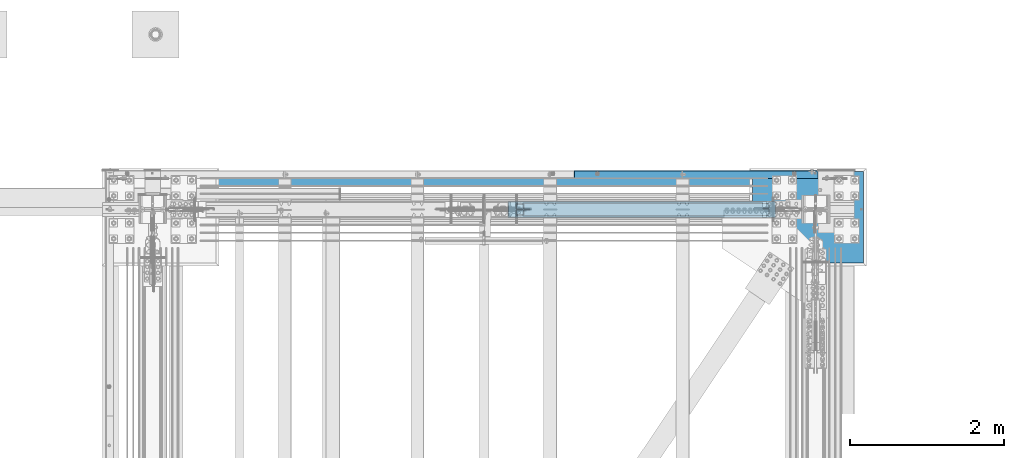
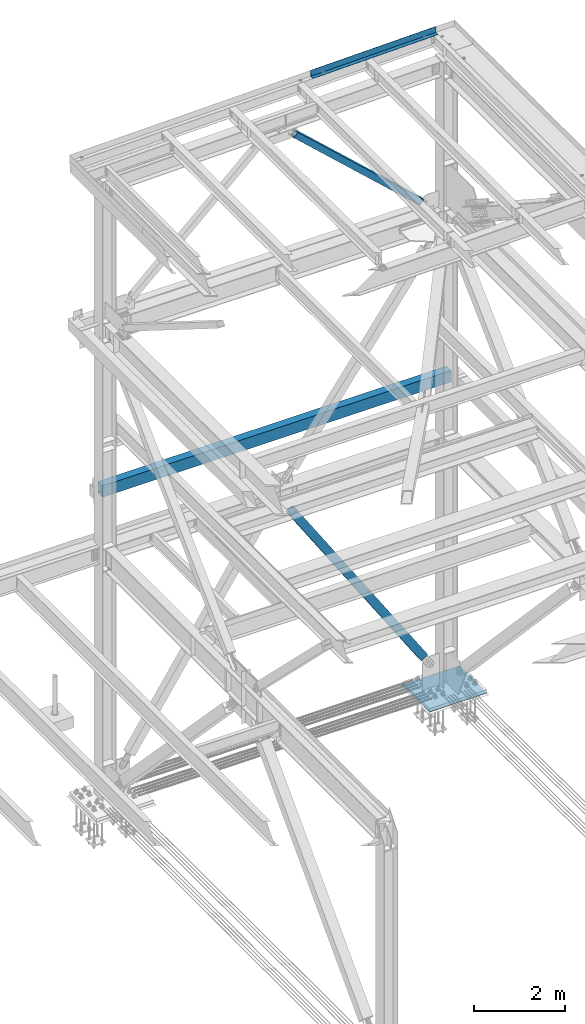
# One storey, part 1999 of 3843: 3 beams, 2 members, 5 elements without a shape of their own.
"""IFC2X3 building model written with IfcOpenShell, lengths in millimetres."""

from ifc_helpers import new_model, si_unit, frame, origin_with_axes, place, context, subcontext, project, spatial, faceted_brep, material, type_object, element, aggregate, save


model = new_model("IFC2X3")

# Units and contexts
model_context = context("Model", 3, precision=1e-05, world=origin_with_axes())
body_context = subcontext(model_context, "Body", "Model", "MODEL_VIEW")
ifc_project = project(units=[si_unit("LENGTHUNIT", "METRE", prefix="MILLI"), si_unit("AREAUNIT", "SQUARE_METRE"), si_unit("VOLUMEUNIT", "CUBIC_METRE"), si_unit("MASSUNIT", "GRAM", prefix="KILO"), si_unit("TIMEUNIT", "SECOND"), si_unit("PLANEANGLEUNIT", "RADIAN"), si_unit("SOLIDANGLEUNIT", "STERADIAN"), si_unit("THERMODYNAMICTEMPERATUREUNIT", "DEGREE_CELSIUS"), si_unit("LUMINOUSINTENSITYUNIT", "LUMEN")], contexts=[model_context])

# Site, building, storey
site_placement = place(None, origin_with_axes())
site = spatial("IfcSite", under=ifc_project, at=site_placement, CompositionType="ELEMENT")
building_placement = place(site_placement, origin_with_axes())
building = spatial("IfcBuilding", under=site, at=building_placement, Name="Undefined", CompositionType="ELEMENT")
storey_placement = place(building_placement, origin_with_axes())
storey = spatial("IfcBuildingStorey", under=building, at=storey_placement, Name="Undefined", CompositionType="ELEMENT", Elevation=0.0)

# Assembly, beam
assembly_1_placement = place(storey_placement, origin_with_axes())
assembly_1 = element("IfcElementAssembly", 1, at=assembly_1_placement, inside=storey, Name="CHANNEL", AssemblyPlace="NOTDEFINED", PredefinedType="RIGID_FRAME")
ifc_material_1 = material(Name="STEEL/A36")
beam_type_1 = type_object("IfcBeamType", PredefinedType="NOTDEFINED")
beam_1_placement = place(assembly_1_placement, frame((84091.2623867946, 104965.500002125, 46738.0427394324), z_axis=(0.999776270257024, 0.0, 0.0211520550054619), x_axis=(0.0, 1.0, 0.0)))
beam_1 = element("IfcBeam", 2, at=beam_1_placement, type_object=beam_type_1, material=ifc_material_1, Name="BENT_PLATE", context=body_context, shape_type="Brep", body=[
    faceted_brep([(-2.34649633057415e-10, -3.19123500958085e-08, -1587.50000000896), (-2.03726813197136e-10, 3.17499999866413, -1584.32499992958), (95.2499978755513, 3.17499999753636, -1584.32499992961), (98.4249979392425, -3.20796971209347e-08, -1587.50000000898), (95.2499978671112, 161.925002134529, -1584.32499992978), (98.4249979464657, 161.925002134696, -1587.50000000915), (95.249997876308, 3.17500000022119, 1587.50000000898), (95.249997867475, 161.92500213749, 1587.5000000088), (-2.7648638933897e-10, -3.17500000133441, -1587.50000000895), (2.29192664846778e-10, -3.17500000135624, 1587.50000000901), (2.40106601268053e-10, 3.17499999863503, 1587.50000000901), (101.599997875906, -3.17500000253494, -1587.50000000896), (101.599997876649, -3.17499999983556, 1587.50000000899), (101.599997867466, 161.925002137839, 1587.50000000882), (101.599997867103, 161.925002134871, -1587.50000000915)], [[[0, 1, 2, 3]], [[3, 2, 4, 5]], [[6, 7, 4, 2]], [[8, 9, 10, 1, 0]], [[10, 6, 2, 1]], [[9, 8, 11, 12]], [[6, 10, 9, 12, 13, 7]], [[12, 11, 14, 13]], [[14, 11, 8, 0, 3, 5]], [[7, 13, 14, 5, 4]]]),
])
aggregate(assembly_1, [beam_1])

assembly_2_placement = place(storey_placement, origin_with_axes())
assembly_2 = element("IfcElementAssembly", 3, at=assembly_2_placement, inside=storey, Name="GIRT", AssemblyPlace="NOTDEFINED", PredefinedType="RIGID_FRAME")
ifc_material_2 = material()
beam_type_2 = type_object("IfcBeamType", Name="HSS12X8X3/8", PredefinedType="NOTDEFINED")
beam_2_placement = place(assembly_2_placement, frame((77115.9870000122, 104965.5, 37592.0), z_axis=(0.0, 0.0, 1.0), x_axis=(1.0, 0.0, 0.0)))
beam_2 = element("IfcBeam", 4, at=beam_2_placement, type_object=beam_type_2, material=ifc_material_2, Name="GIRT", ObjectType="HSS12X8X3/8", context=body_context, shape_type="Brep", body=[
    faceted_brep([(0.0, 92.0749999999971, -142.875), (0.0, -92.0749999999971, -142.875), (8836.0260000682, -92.0749999999971, -142.875), (8836.0260000682, 92.0749999999971, -142.875), (0.0, -92.0749999999971, 142.875), (8836.0260000682, -92.0749999999971, 142.875), (0.0, 92.0749999999971, 142.875), (8836.0260000682, 92.0749999999971, 142.875), (0.0, 101.600000000006, -152.400000000001), (0.0, 101.600000000006, 152.400000000001), (8836.0260000682, 101.600000000006, 152.400000000001), (8836.0260000682, 101.600000000006, -152.400000000001), (0.0, -101.600000000006, 152.400000000001), (8836.0260000682, -101.600000000006, 152.400000000001), (0.0, -101.600000000006, -152.400000000001), (8836.0260000682, -101.600000000006, -152.400000000001)], [[[0, 1, 2, 3]], [[1, 4, 5, 2]], [[4, 6, 7, 5]], [[6, 0, 3, 7]], [[8, 9, 10, 11]], [[9, 12, 13, 10]], [[12, 14, 15, 13]], [[14, 8, 11, 15]], [[13, 15, 11, 10], [5, 7, 3, 2]], [[14, 12, 9, 8], [6, 4, 1, 0]]]),
])
aggregate(assembly_2, [beam_2])

# Assembly, member
assembly_3_placement = place(storey_placement, origin_with_axes())
assembly_3 = element("IfcElementAssembly", 5, at=assembly_3_placement, inside=storey, Name="None", AssemblyPlace="NOTDEFINED", PredefinedType="RIGID_FRAME")
ifc_material_3 = material(Name="STEEL/A992")
member_type_1 = type_object("IfcMemberType", Name="HSS8X8X3/16", PredefinedType="NOTDEFINED")
member_1_placement = place(assembly_3_placement, frame((85041.2826195981, 104559.1, 30615.4903740521), z_axis=(0.0, 1.0, 0.0), x_axis=(-0.549839243795952, 0.0, 0.835270498690032)))
member_1 = element("IfcMember", 6, at=member_1_placement, type_object=member_type_1, material=ifc_material_3, Name="None", ObjectType="HSS8X8X3/16", context=body_context, shape_type="Brep", body=[
    faceted_brep([(2.03726813197136e-10, 96.8375000003298, -96.8374999999942), (-2.18278728425503e-10, -96.837500000317, -96.8374999999942), (6026.15000014934, -96.8375000308661, -96.8374999999942), (6026.15000014917, 96.837499969035, -96.8374999999942), (-2.18278728425503e-10, -96.837500000317, 96.8374999999942), (6026.15000014934, -96.8375000308661, 96.8374999999942), (2.03726813197136e-10, 96.8375000003298, 96.8374999999942), (6026.15000014917, 96.837499969035, 96.8374999999942), (2.18278728425503e-10, 101.600000000345, -101.600000000006), (2.18278728425503e-10, 101.600000000345, 101.600000000006), (6026.15000014915, 101.599999969032, 101.600000000006), (6026.15000014915, 101.599999969032, -101.600000000006), (-2.25554686039686e-10, -101.600000000329, 101.600000000006), (6026.15000014936, -101.600000030849, 101.600000000006), (-2.25554686039686e-10, -101.600000000329, -101.600000000006), (6026.15000014936, -101.600000030849, -101.600000000006)], [[[0, 1, 2, 3]], [[1, 4, 5, 2]], [[4, 6, 7, 5]], [[6, 0, 3, 7]], [[8, 9, 10, 11]], [[9, 12, 13, 10]], [[12, 14, 15, 13]], [[14, 8, 11, 15]], [[13, 15, 11, 10], [5, 7, 3, 2]], [[14, 12, 9, 8], [6, 4, 1, 0]]]),
])
aggregate(assembly_3, [member_1])

assembly_4_placement = place(storey_placement, origin_with_axes())
assembly_4 = element("IfcElementAssembly", 7, at=assembly_4_placement, inside=storey, AssemblyPlace="NOTDEFINED", PredefinedType="RIGID_FRAME")
member_type_2 = type_object("IfcMemberType", Name="HSS6X6X3/8", PredefinedType="NOTDEFINED")
member_2_placement = place(assembly_4_placement, frame((81330.7999999182, 104559.100000322, 46157.2357398702), z_axis=(0.675885212782435, 0.0, 0.737006905762791), x_axis=(0.737006905762768, 0.0, -0.67588521278246)))
member_2 = element("IfcMember", 8, at=member_2_placement, type_object=member_type_2, material=ifc_material_2, ObjectType="HSS6X6X3/8", context=body_context, shape_type="Brep", body=[
    faceted_brep([(4968.00291192122, 20.6374999999971, 76.2000000086555), (4867.9904119204, 20.6374999999971, 76.2000000084809), (4867.99041192041, 20.6374999999971, 66.6750000084721), (4968.00291192122, 20.6374999999971, 66.6750000086467), (4864.95286217598, 20.0332937893108, 76.2000000084663), (4864.95286217601, 20.0332937893108, 66.6750000084721), (4862.3777518447, 18.3126600756659, 76.2000000084809), (4862.37775184472, 18.3126600756659, 66.6750000084576), (4860.65711813106, 15.7375497444009, 76.2000000084663), (4860.65711813106, 15.7375497444009, 66.6750000084576), (4860.05291192036, 12.6999999999971, 76.2000000084663), (4860.05291192038, 12.6999999999971, 66.6750000084576), (4860.65711813106, 9.66245025559328, 76.2000000084663), (4860.65711813106, 9.66245025559328, 66.6750000084576), (4862.3777518447, 7.08733992432826, 76.2000000084809), (4862.37775184472, 7.08733992432826, 66.6750000084576), (4864.95286217598, 5.36670621068333, 76.2000000084663), (4864.95286217601, 5.36670621068333, 66.6750000084721), (4867.9904119204, 4.76249999999709, 76.2000000084809), (4867.99041192041, 4.76249999999709, 66.6750000084721), (4968.00291192122, 4.76249999999709, 76.2000000086555), (4968.00291192122, 4.76249999999709, 66.6750000086467), (4968.00291192122, 20.6374999999971, -66.6749999915919), (4867.99041192065, 20.6374999999971, -66.674999991752), (4867.99041192067, 20.6374999999971, -76.1999999917607), (4968.00291192122, 20.6374999999971, -76.1999999916006), (4864.95286217624, 20.0332937893108, -66.6749999917665), (4864.95286217624, 20.0332937893108, -76.1999999917753), (4862.37775184496, 18.3126600756659, -66.674999991752), (4862.37775184497, 18.3126600756659, -76.1999999917753), (4860.6571181313, 15.7375497444009, -66.6749999917665), (4860.65711813133, 15.7375497444009, -76.1999999917753), (4860.05291192061, 12.6999999999971, -66.6749999917665), (4860.05291192063, 12.6999999999971, -76.1999999917753), (4860.6571181313, 9.66245025559328, -66.6749999917665), (4860.65711813133, 9.66245025559328, -76.1999999917753), (4862.37775184496, 7.08733992432826, -66.674999991752), (4862.37775184497, 7.08733992432826, -76.1999999917753), (4864.95286217624, 5.36670621068333, -66.6749999917665), (4864.95286217624, 5.36670621068333, -76.1999999917753), (4867.99041192065, 4.76249999999709, -66.674999991752), (4867.99041192067, 4.76249999999709, -76.1999999917607), (4968.00291192122, 4.76249999999709, -66.6749999915919), (4968.00291192122, 4.76249999999709, -76.1999999916006), (634.247749729708, 66.6750000000029, 66.6750000011962), (634.247749729708, 66.6750000000029, -66.6749999990134), (4968.00291192122, 66.6750000000029, -66.6749999915919), (4968.00291192122, 66.6750000000029, 66.6750000086467), (4968.00291192122, -66.6750000000029, 66.6750000086467), (634.247749729708, -66.6750000000029, 66.6750000011962), (634.247749729708, -7.93749986813054, 66.6750000011962), (734.260249733903, -7.93749986813054, 66.6750000013708), (737.297799478325, -7.3332936574443, 66.6750000013853), (739.872909809601, -5.61265994379937, 66.6750000013853), (741.59354352325, -3.03754961253435, 66.6750000013853), (742.197749733943, 1.3186945579946e-07, 66.6750000013999), (741.59354352325, 3.03754987627326, 66.6750000013853), (739.872909809601, 5.61266020753828, 66.6750000013853), (737.297799478325, 7.33329392118321, 66.6750000013853), (734.260249733903, 7.93750013186946, 66.6750000013708), (634.247749729708, 7.93750013186946, 66.6750000011962), (634.247749729708, -66.6750000000029, -66.6749999990134), (4968.00291192122, -66.6750000000029, -66.6749999915919), (634.247749729708, 7.93750013186946, -66.6749999990134), (734.260249734132, 7.93750013186946, -66.6749999988533), (737.29779947854, 7.33329392118321, -66.6749999988388), (739.872909809819, 5.61266020753828, -66.6749999988388), (741.593543523468, 3.03754987627326, -66.6749999988388), (742.197749734176, 1.3186945579946e-07, -66.6749999988388), (741.593543523468, -3.03754961253435, -66.6749999988388), (739.872909809819, -5.61265994379937, -66.6749999988388), (737.29779947854, -7.3332936574443, -66.6749999988388), (734.260249734132, -7.93749986813054, -66.6749999988533), (634.247749729708, -7.93749986813054, -66.6749999990134), (634.247749729708, 7.93750013186946, -76.1999999990367), (734.260249734143, 7.93750013186946, -76.199999998862), (737.297799478558, 7.33329392118321, -76.199999998862), (739.872909809848, 5.61266020753828, -76.1999999988475), (741.593543523501, 3.03754987627326, -76.1999999988475), (742.197749734187, 1.3186945579946e-07, -76.1999999988475), (741.593543523501, -3.03754961253435, -76.1999999988475), (739.872909809848, -5.61265994379937, -76.1999999988475), (737.297799478558, -7.3332936574443, -76.199999998862), (734.260249734143, -7.93749986813054, -76.199999998862), (634.247749729708, -7.93749986813054, -76.1999999990367), (634.247749729708, -76.1999999999971, -76.1999999990367), (634.247749729704, -76.1999999999971, 76.2000000012195), (634.247749729704, -7.93749986813054, 76.2000000012195), (734.260249733888, -7.93749986813054, 76.2000000013941), (737.297799478292, -7.3332936574443, 76.2000000013941), (739.872909809583, -5.61265994379937, 76.2000000013941), (741.593543523235, -3.03754961253435, 76.2000000013941), (742.197749733929, 1.3186945579946e-07, 76.2000000013941), (741.593543523235, 3.03754987627326, 76.2000000013941), (739.872909809583, 5.61266020753828, 76.2000000013941), (737.297799478292, 7.33329392118321, 76.2000000013941), (734.260249733888, 7.93750013186946, 76.2000000013941), (634.247749729704, 7.93750013186946, 76.2000000012195), (634.247749729704, 76.1999999999971, 76.2000000012195), (634.247749729708, 76.1999999999971, -76.1999999990367), (4968.00291192122, 76.1999999999971, 76.2000000086555), (4968.00291192122, 76.1999999999971, -76.1999999916006), (4968.00291192122, -76.1999999999971, -76.1999999916006), (4968.00291192122, -76.1999999999971, 76.2000000086555)], [[[0, 1, 2, 3]], [[4, 5, 2, 1]], [[6, 7, 5, 4]], [[8, 9, 7, 6]], [[10, 11, 9, 8]], [[12, 13, 11, 10]], [[14, 15, 13, 12]], [[16, 17, 15, 14]], [[18, 19, 17, 16]], [[20, 21, 19, 18]], [[22, 23, 24, 25]], [[26, 27, 24, 23]], [[28, 29, 27, 26]], [[30, 31, 29, 28]], [[32, 33, 31, 30]], [[34, 35, 33, 32]], [[36, 37, 35, 34]], [[38, 39, 37, 36]], [[40, 41, 39, 38]], [[42, 43, 41, 40]], [[44, 45, 46, 47]], [[48, 49, 50, 51, 52, 53, 54, 55, 56, 57, 58, 59, 60, 44, 47, 3, 2, 5, 7, 9, 11, 13, 15, 17, 19, 21]], [[61, 49, 48, 62]], [[38, 36, 34, 32, 30, 28, 26, 23, 22, 46, 45, 63, 64, 65, 66, 67, 68, 69, 70, 71, 72, 73, 61, 62, 42, 40]], [[63, 74, 75, 64]], [[64, 75, 76, 65]], [[65, 76, 77, 66]], [[66, 77, 78, 67]], [[67, 78, 79, 68]], [[68, 79, 80, 69]], [[69, 80, 81, 70]], [[70, 81, 82, 71]], [[71, 82, 83, 72]], [[72, 83, 84, 73]], [[49, 61, 73, 84, 85, 86, 87, 50]], [[88, 51, 50, 87]], [[89, 52, 51, 88]], [[90, 53, 52, 89]], [[91, 54, 53, 90]], [[92, 55, 54, 91]], [[93, 56, 55, 92]], [[94, 57, 56, 93]], [[95, 58, 57, 94]], [[96, 59, 58, 95]], [[97, 60, 59, 96]], [[98, 99, 74, 63, 45, 44, 60, 97]], [[99, 98, 100, 101]], [[47, 46, 22, 25, 101, 100, 0, 3]], [[102, 85, 84, 83, 82, 81, 80, 79, 78, 77, 76, 75, 74, 99, 101, 25, 24, 27, 29, 31, 33, 35, 37, 39, 41, 43]], [[86, 85, 102, 103]], [[16, 14, 12, 10, 8, 6, 4, 1, 0, 100, 98, 97, 96, 95, 94, 93, 92, 91, 90, 89, 88, 87, 86, 103, 20, 18]], [[103, 102, 43, 42, 62, 48, 21, 20]]]),
])
aggregate(assembly_4, [member_2])

# Assembly, beam
assembly_5_placement = place(storey_placement, origin_with_axes())
assembly_5 = element("IfcElementAssembly", 9, at=assembly_5_placement, inside=storey, Name="TEMPLATE", AssemblyPlace="NOTDEFINED", PredefinedType="RIGID_FRAME")
ifc_material_4 = material(Name="STEEL/A572-50")
beam_type_3 = type_object("IfcBeamType", PredefinedType="NOTDEFINED")
beam_3_placement = place(assembly_5_placement, frame((86271.1, 104457.5, 29608.4625), z_axis=(0.0, -1.0, 0.0), x_axis=(-1.0, 0.0, 0.0)))
beam_3 = element("IfcBeam", 10, at=beam_3_placement, type_object=beam_type_3, material=ifc_material_4, Name="TEMPLATE", context=body_context, shape_type="Brep", body=[
    faceted_brep([(0.0, 4.76250000000073, -596.899999999994), (0.0, 4.76250000000073, 596.899999999994), (1447.8, 4.76250000000073, 596.899999999994), (1447.8, 4.76250000000073, -596.899999999994), (0.0, -4.76250000000073, 596.899999999994), (1447.8, -4.76250000000073, 596.899999999994), (0.0, -4.76250000000073, -596.899999999994), (1447.8, -4.76250000000073, -596.899999999994)], [[[0, 1, 2, 3]], [[1, 4, 5, 2]], [[4, 6, 7, 5]], [[6, 0, 3, 7]], [[5, 7, 3, 2]], [[6, 4, 1, 0]]]),
])
aggregate(assembly_5, [beam_3])

save(model, "model.ifc")
